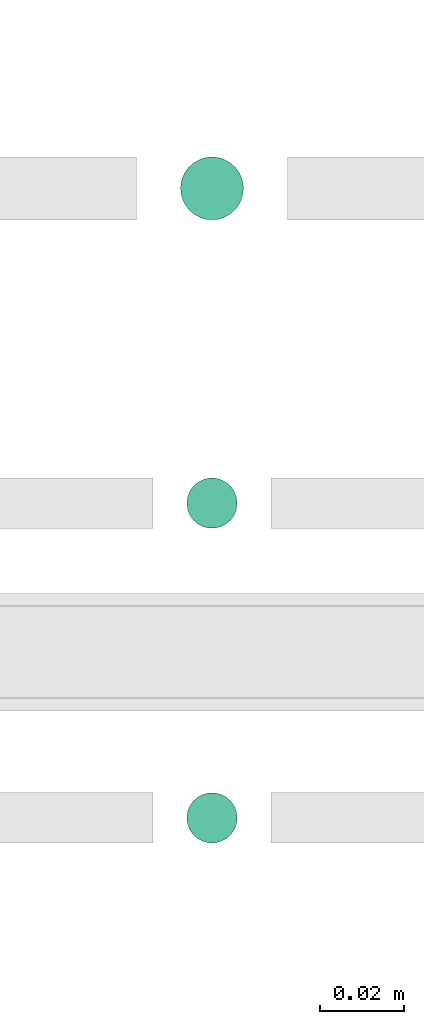
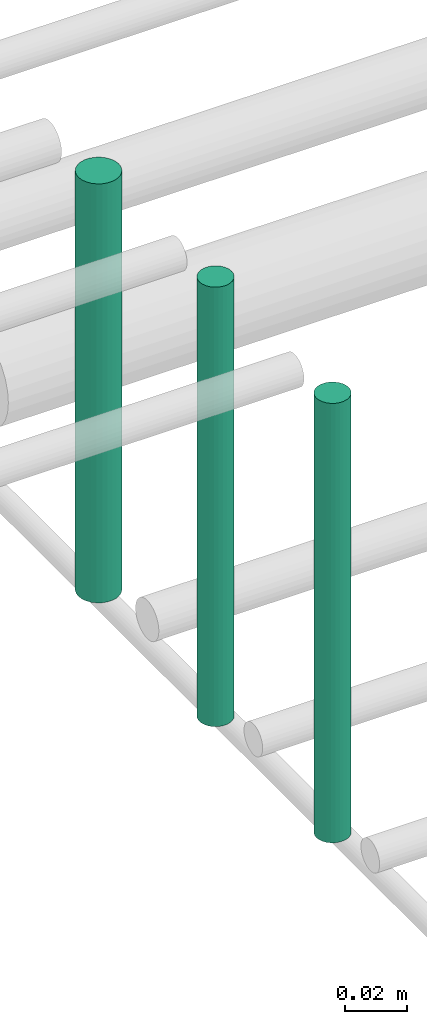
# One storey, part 179 of 331: 3 flow segments.
"""IFC2X3 building model written with IfcOpenShell, lengths in millimetres."""

from ifc_helpers import new_model, entity, si_unit, converted_unit, derived_unit, direction, frame, frame_2d, origin, origin_2d_with_axis, place, context, subcontext, project, spatial, circle, extrude, type_object, element, save


model = new_model("IFC2X3")

# Units and contexts
model_context = context("Model", 3, precision=0.01, world=origin(), true_north=direction((6.12303176911189e-17, 1.0)))
body_context = subcontext(model_context, "Body", "Model", "MODEL_VIEW")
ifc_project = project(units=[si_unit("LENGTHUNIT", "METRE", prefix="MILLI"), si_unit("AREAUNIT", "SQUARE_METRE"), si_unit("VOLUMEUNIT", "CUBIC_METRE"), converted_unit("PLANEANGLEUNIT", "DEGREE", entity("IfcRatioMeasure", 0.0174532925199433), si_unit("PLANEANGLEUNIT", "RADIAN"), dimensions=[0, 0, 0, 0, 0, 0, 0]), si_unit("MASSUNIT", "GRAM", prefix="KILO"), derived_unit("MASSDENSITYUNIT", [(si_unit("MASSUNIT", "GRAM", prefix="KILO"), 1), (si_unit("LENGTHUNIT", "METRE"), -3)]), derived_unit("MOMENTOFINERTIAUNIT", [(si_unit("LENGTHUNIT", "METRE"), 4)]), si_unit("TIMEUNIT", "SECOND"), si_unit("FREQUENCYUNIT", "HERTZ"), si_unit("THERMODYNAMICTEMPERATUREUNIT", "DEGREE_CELSIUS"), derived_unit("THERMALTRANSMITTANCEUNIT", [(si_unit("MASSUNIT", "GRAM", prefix="KILO"), 1), (si_unit("THERMODYNAMICTEMPERATUREUNIT", "KELVIN"), -1), (si_unit("TIMEUNIT", "SECOND"), -3)]), derived_unit("VOLUMETRICFLOWRATEUNIT", [(si_unit("LENGTHUNIT", "METRE"), 3), (si_unit("TIMEUNIT", "SECOND"), -1)]), derived_unit("MASSFLOWRATEUNIT", [(si_unit("MASSUNIT", "GRAM", prefix="KILO"), 1), (si_unit("TIMEUNIT", "SECOND"), -1)]), derived_unit("ROTATIONALFREQUENCYUNIT", [(si_unit("TIMEUNIT", "SECOND"), -1)]), si_unit("ELECTRICCURRENTUNIT", "AMPERE"), si_unit("ELECTRICVOLTAGEUNIT", "VOLT"), si_unit("POWERUNIT", "WATT"), si_unit("FORCEUNIT", "NEWTON", prefix="KILO"), si_unit("ILLUMINANCEUNIT", "LUX"), si_unit("LUMINOUSFLUXUNIT", "LUMEN"), si_unit("LUMINOUSINTENSITYUNIT", "CANDELA"), derived_unit("USERDEFINED", [(si_unit("MASSUNIT", "GRAM", prefix="KILO"), -1), (si_unit("LENGTHUNIT", "METRE"), -2), (si_unit("TIMEUNIT", "SECOND"), 3), (si_unit("LUMINOUSFLUXUNIT", "LUMEN"), 1)]), derived_unit("LINEARVELOCITYUNIT", [(si_unit("LENGTHUNIT", "METRE"), 1), (si_unit("TIMEUNIT", "SECOND"), -1)]), si_unit("PRESSUREUNIT", "PASCAL"), derived_unit("USERDEFINED", [(si_unit("LENGTHUNIT", "METRE"), -2), (si_unit("MASSUNIT", "GRAM", prefix="KILO"), 1), (si_unit("TIMEUNIT", "SECOND"), -2)]), derived_unit("LINEARFORCEUNIT", [(si_unit("MASSUNIT", "GRAM", prefix="KILO"), 1), (si_unit("LENGTHUNIT", "METRE"), 1), (si_unit("TIMEUNIT", "SECOND"), -2), (si_unit("LENGTHUNIT", "METRE"), -1)]), derived_unit("PLANARFORCEUNIT", [(si_unit("MASSUNIT", "GRAM", prefix="KILO"), 1), (si_unit("LENGTHUNIT", "METRE"), 1), (si_unit("TIMEUNIT", "SECOND"), -2), (si_unit("LENGTHUNIT", "METRE"), -2)])], contexts=[model_context])

# Site, building, storey
site_placement = place(None, frame((0.0, -0.00077364408347762, 0.0)))
site = spatial("IfcSite", under=ifc_project, at=site_placement, CompositionType="ELEMENT")
building_placement = place(site_placement, origin())
building = spatial("IfcBuilding", under=site, at=building_placement, CompositionType="ELEMENT")
storey_placement = place(building_placement, origin())
storey = spatial("IfcBuildingStorey", under=building, at=storey_placement, CompositionType="ELEMENT", Elevation=0.0)

# Flow segments
pipe_segment_type = type_object("IfcPipeSegmentType", PredefinedType="NOTDEFINED")
flow_segment_1_placement = place(storey_placement, frame((41812.0853316717, 8296.91467161339, 14567.9994279912)))
element("IfcFlowSegment", 1, at=flow_segment_1_placement, inside=storey, type_object=pipe_segment_type, context=body_context, shape_type="SweptSolid", body=[
    extrude(circle(Radius=7.5, at=origin_2d_with_axis()), frame((9.09527223591419, 9.09527223591636, 0.0), z_axis=(0.0, 0.0, 1.0), x_axis=(-1.0, 0.0, 0.0)), (0.0, 0.0, 1.0), 164.000889373357),
])
flow_segment_2_placement = place(storey_placement, frame((41813.5853316717, 8223.41467161339, 14563.9990150847)))
element("IfcFlowSegment", 2, at=flow_segment_2_placement, inside=storey, type_object=pipe_segment_type, context=body_context, shape_type="SweptSolid", body=[
    extrude(circle(Radius=6.0, at=origin_2d_with_axis()), frame((7.59527223591454, 7.59527223591562, 0.0), z_axis=(0.0, 0.0, 1.0), x_axis=(-1.0, 0.0, 0.0)), (0.0, 0.0, 1.0), 172.000984915315),
])
flow_segment_3_placement = place(storey_placement, frame((41813.5853316717, 8148.41467161336, 14564.0)))
element("IfcFlowSegment", 3, at=flow_segment_3_placement, inside=storey, type_object=pipe_segment_type, context=body_context, shape_type="SweptSolid", body=[
    extrude(circle(Radius=6.0, at=frame_2d((0.0, -1.08286712929839e-12), x_axis=(1.0, 0.0))), frame((7.59527223591454, 7.59527223591454, 0.0), z_axis=(0.0, 0.0, 1.0), x_axis=(-1.0, 0.0, 0.0)), (0.0, 0.0, 1.0), 172.000000000041),
])

save(model, "model.ifc")
